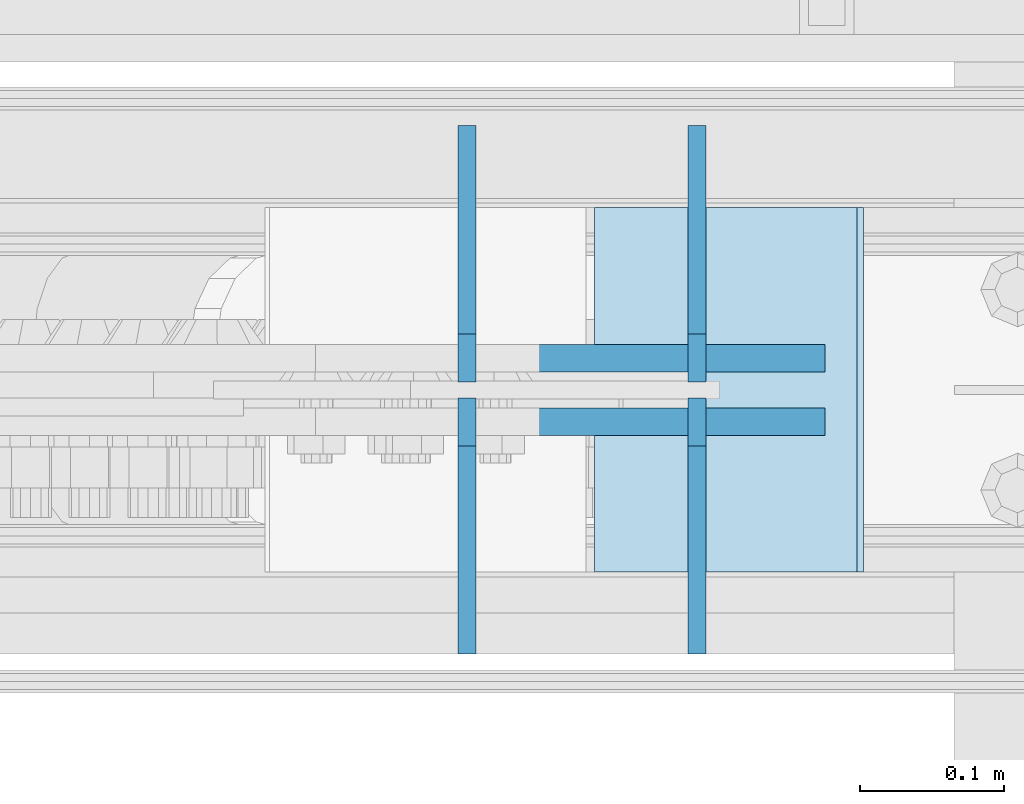
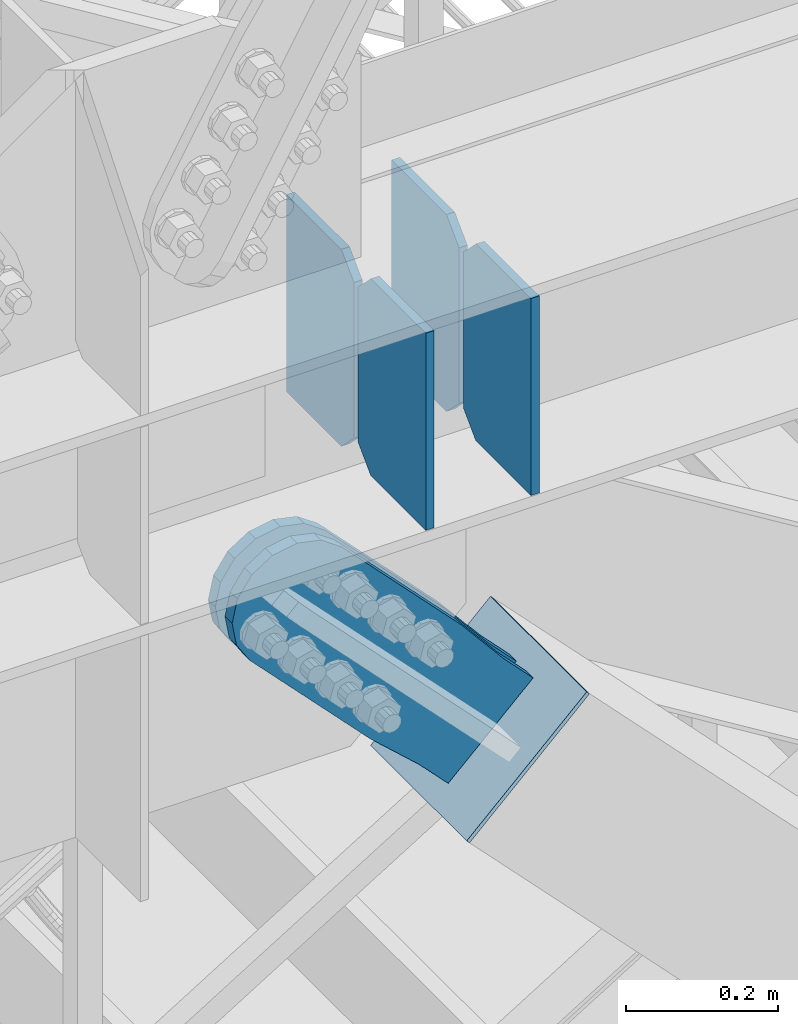
# One storey, part 3553 of 3843: 7 plates, 4 elements without a shape of their own.
"""IFC2X3 building model written with IfcOpenShell, lengths in millimetres."""

from ifc_helpers import new_model, si_unit, frame, origin_with_axes, place, context, subcontext, project, spatial, faceted_brep, material, type_object, element, aggregate, save


model = new_model("IFC2X3")

# Units and contexts
model_context = context("Model", 3, precision=1e-05, world=origin_with_axes())
body_context = subcontext(model_context, "Body", "Model", "MODEL_VIEW")
ifc_project = project(units=[si_unit("LENGTHUNIT", "METRE", prefix="MILLI"), si_unit("AREAUNIT", "SQUARE_METRE"), si_unit("VOLUMEUNIT", "CUBIC_METRE"), si_unit("MASSUNIT", "GRAM", prefix="KILO"), si_unit("TIMEUNIT", "SECOND"), si_unit("PLANEANGLEUNIT", "RADIAN"), si_unit("SOLIDANGLEUNIT", "STERADIAN"), si_unit("THERMODYNAMICTEMPERATUREUNIT", "DEGREE_CELSIUS"), si_unit("LUMINOUSINTENSITYUNIT", "LUMEN")], contexts=[model_context])

# Site, building, storey
site_placement = place(None, origin_with_axes())
site = spatial("IfcSite", under=ifc_project, at=site_placement, CompositionType="ELEMENT")
building_placement = place(site_placement, origin_with_axes())
building = spatial("IfcBuilding", under=site, at=building_placement, Name="Undefined", CompositionType="ELEMENT")
storey_placement = place(building_placement, origin_with_axes())
storey = spatial("IfcBuildingStorey", under=building, at=storey_placement, Name="Undefined", CompositionType="ELEMENT", Elevation=0.0)

# Assembly, plates
assembly_1_placement = place(storey_placement, origin_with_axes())
assembly_1 = element("IfcElementAssembly", 1, at=assembly_1_placement, inside=storey, Name="BEAM", AssemblyPlace="NOTDEFINED", PredefinedType="RIGID_FRAME")
ifc_material_1 = material(Name="STEEL/A572-50")
plate_type_1 = type_object("IfcPlateType", PredefinedType="NOTDEFINED")
plate_1_placement = place(assembly_1_placement, frame((81765.9734379999, 15004.25625, 34474.15), z_axis=(0.0, 1.0, 0.0), x_axis=(0.0, 0.0, 1.0)))
plate_1 = element("IfcPlate", 2, at=plate_1_placement, type_object=plate_type_1, material=ifc_material_1, Name="CB_BEAM", context=body_context, shape_type="Brep", body=[
    faceted_brep([(0.0, -6.34999999999854, 33.3375015258789), (0.0, -6.34999999999854, 178.59375), (0.0, 6.34999999999854, 178.59375), (0.0, 6.34999999999854, 33.3375015258789), (317.499999999985, -6.34999999999854, 178.59375), (317.499999999985, 6.34999999999854, 178.59375), (317.499999999985, -6.34999999999854, 33.3375015258789), (317.499999999985, 6.34999999999854, 33.3375015258789), (284.162498474107, -6.34999999999854, 0.0), (284.162498474107, 6.34999999999854, 0.0), (33.3375015258789, -6.34999999999854, 0.0), (33.3375015258789, 6.34999999999854, 0.0)], [[[0, 1, 2, 3]], [[1, 4, 5, 2]], [[4, 6, 7, 5]], [[6, 8, 9, 7]], [[8, 10, 11, 9]], [[10, 0, 3, 11]], [[5, 7, 9, 11, 3, 2]], [[10, 8, 6, 4, 1, 0]]]),
])
plate_2_placement = place(assembly_1_placement, frame((81765.9734379999, 14993.14375, 34474.15), z_axis=(0.0, -1.0, 0.0), x_axis=(0.0, 0.0, 1.0)))
plate_2 = element("IfcPlate", 3, at=plate_2_placement, type_object=plate_type_1, material=ifc_material_1, Name="CB_BEAM", context=body_context, shape_type="Brep", body=[
    faceted_brep([(0.0, -6.34999999999854, 33.3375015258789), (0.0, -6.34999999999854, 178.59375), (0.0, 6.34999999999854, 178.59375), (0.0, 6.34999999999854, 33.3375015258789), (317.499999999985, -6.34999999999854, 178.59375), (317.499999999985, 6.34999999999854, 178.59375), (317.499999999985, -6.34999999999854, 33.3375015258789), (317.499999999985, 6.34999999999854, 33.3375015258789), (284.162498474107, -6.34999999999854, 0.0), (284.162498474107, 6.34999999999854, 0.0), (33.3375015258789, -6.34999999999854, 0.0), (33.3375015258789, 6.34999999999854, 0.0)], [[[0, 1, 2, 3]], [[1, 4, 5, 2]], [[4, 6, 7, 5]], [[6, 8, 9, 7]], [[8, 10, 11, 9]], [[10, 0, 3, 11]], [[5, 7, 9, 11, 3, 2]], [[10, 8, 6, 4, 1, 0]]]),
])
plate_3_placement = place(assembly_1_placement, frame((81926.1124999999, 15004.25625, 34474.15), z_axis=(0.0, 1.0, 0.0), x_axis=(0.0, 0.0, 1.0)))
plate_3 = element("IfcPlate", 4, at=plate_3_placement, type_object=plate_type_1, material=ifc_material_1, Name="CB_BEAM", context=body_context, shape_type="Brep", body=[
    faceted_brep([(0.0, -6.34999999999854, 33.3375015258789), (0.0, -6.34999999999854, 178.59375), (0.0, 6.34999999999854, 178.59375), (0.0, 6.34999999999854, 33.3375015258789), (317.499999999985, -6.34999999999854, 178.59375), (317.499999999985, 6.34999999999854, 178.59375), (317.499999999985, -6.34999999999854, 33.3375015258789), (317.499999999985, 6.34999999999854, 33.3375015258789), (284.162498474107, -6.34999999999854, 0.0), (284.162498474107, 6.34999999999854, 0.0), (33.3375015258789, -6.34999999999854, 0.0), (33.3375015258789, 6.34999999999854, 0.0)], [[[0, 1, 2, 3]], [[1, 4, 5, 2]], [[4, 6, 7, 5]], [[6, 8, 9, 7]], [[8, 10, 11, 9]], [[10, 0, 3, 11]], [[5, 7, 9, 11, 3, 2]], [[10, 8, 6, 4, 1, 0]]]),
])
plate_4_placement = place(assembly_1_placement, frame((81926.1124999999, 14993.14375, 34474.15), z_axis=(0.0, -1.0, 0.0), x_axis=(0.0, 0.0, 1.0)))
plate_4 = element("IfcPlate", 5, at=plate_4_placement, type_object=plate_type_1, material=ifc_material_1, Name="CB_BEAM", context=body_context, shape_type="Brep", body=[
    faceted_brep([(0.0, -6.34999999999854, 33.3375015258789), (0.0, -6.34999999999854, 178.59375), (0.0, 6.34999999999854, 178.59375), (0.0, 6.34999999999854, 33.3375015258789), (317.499999999985, -6.34999999999854, 178.59375), (317.499999999985, 6.34999999999854, 178.59375), (317.499999999985, -6.34999999999854, 33.3375015258789), (317.499999999985, 6.34999999999854, 33.3375015258789), (284.162498474107, -6.34999999999854, 0.0), (284.162498474107, 6.34999999999854, 0.0), (33.3375015258789, -6.34999999999854, 0.0), (33.3375015258789, 6.34999999999854, 0.0)], [[[0, 1, 2, 3]], [[1, 4, 5, 2]], [[4, 6, 7, 5]], [[6, 8, 9, 7]], [[8, 10, 11, 9]], [[10, 0, 3, 11]], [[5, 7, 9, 11, 3, 2]], [[10, 8, 6, 4, 1, 0]]]),
])
aggregate(assembly_1, [plate_1, plate_2, plate_3, plate_4])

# Assembly, plate
assembly_2_placement = place(storey_placement, origin_with_axes())
assembly_2 = element("IfcElementAssembly", 6, at=assembly_2_placement, inside=storey, AssemblyPlace="NOTDEFINED", PredefinedType="RIGID_FRAME")
ifc_material_2 = material(Name="STEEL/A36")
plate_type_2 = type_object("IfcPlateType", PredefinedType="NOTDEFINED")
plate_5_placement = place(assembly_2_placement, frame((81966.9397793737, 15020.925, 34101.9215132179), z_axis=(-0.720244694304652, 0.0, -0.693720102293424), x_axis=(0.693720102293427, 0.0, -0.720244694304649)))
plate_5 = element("IfcPlate", 7, at=plate_5_placement, type_object=plate_type_2, material=ifc_material_2, context=body_context, shape_type="Brep", body=[
    faceted_brep([(0.0, -9.52500000000146, 0.0), (-101.59999999866, -9.52499999999418, -7.01164927375794), (-101.59999999866, 9.52499999999418, -7.01164927375794), (0.0, 9.52500000000146, 0.0), (-364.729297655074, -9.52499999999418, -7.01164927444188), (-364.729297655074, 9.52499999999418, -7.01164927444188), (-401.787405121293, -9.52499999999418, 0.359666612348519), (-401.787405121293, 9.52499999999418, 0.359666612348519), (-433.203751657995, -9.52499999999418, 21.3513982502482), (-433.203751657995, 9.52499999999418, 21.3513982502482), (-454.195483294687, -9.52499999999418, 52.7677447877504), (-454.195483294687, 9.52499999999418, 52.7677447877504), (-461.566799180051, -9.52499999999418, 89.8258492000314), (-461.566799180051, 9.52499999999418, 89.8258492000314), (-454.195483292249, -9.52499999999418, 126.883956664562), (-454.195483292249, 9.52499999999418, 126.883956664562), (-433.203751654662, -9.52499999999418, 158.300303199998), (-433.203751654662, 9.52499999999418, 158.300303199998), (-401.787405118426, -9.52499999999418, 179.292034836384), (-401.787405118426, 9.52499999999418, 179.292034836384), (-364.729299177612, -9.52499999999418, 186.663350722738), (-364.729299177612, 9.52499999999418, 186.663350722738), (-101.5999999907, -9.52499999999418, 186.663350723451), (-101.5999999907, 9.52499999999418, 186.663350723451), (7.37782102078199e-09, -9.52499999999418, 179.651701450231), (7.37782102078199e-09, 9.52499999999418, 179.651701450231), (69.8500000062704, -9.52499999999418, 179.651701450392), (69.8500000062704, 9.52499999999418, 179.651701450392), (69.8499999979995, -9.52499999999418, -4.00177668780088e-10), (69.8499999979995, 9.52499999999418, -4.00177668780088e-10)], [[[0, 1, 2, 3]], [[1, 4, 5, 2]], [[4, 6, 7, 5]], [[6, 8, 9, 7]], [[8, 10, 11, 9]], [[10, 12, 13, 11]], [[12, 14, 15, 13]], [[14, 16, 17, 15]], [[16, 18, 19, 17]], [[18, 20, 21, 19]], [[20, 22, 23, 21]], [[22, 24, 25, 23]], [[24, 26, 27, 25]], [[26, 28, 29, 27]], [[28, 0, 3, 29]], [[5, 7, 9, 11, 13, 15, 17, 19, 21, 23, 25, 27, 29, 3, 2]], [[28, 26, 24, 22, 20, 18, 16, 14, 12, 10, 8, 6, 4, 1, 0]]]),
])
aggregate(assembly_2, [plate_5])

assembly_3_placement = place(storey_placement, origin_with_axes())
assembly_3 = element("IfcElementAssembly", 8, at=assembly_3_placement, inside=storey, AssemblyPlace="NOTDEFINED", PredefinedType="RIGID_FRAME")
plate_6_placement = place(assembly_3_placement, frame((81966.9397793737, 14976.475, 34101.9215132179), z_axis=(-0.720244694304652, 0.0, -0.693720102293424), x_axis=(0.693720102293427, 0.0, -0.720244694304649)))
plate_6 = element("IfcPlate", 9, at=plate_6_placement, type_object=plate_type_2, material=ifc_material_2, context=body_context, shape_type="Brep", body=[
    faceted_brep([(0.0, -9.52500000000146, 0.0), (-101.59999999866, -9.52499999999418, -7.01164927375794), (-101.59999999866, 9.52499999999418, -7.01164927375794), (0.0, 9.52500000000146, 0.0), (-364.729297655074, -9.52499999999418, -7.01164927444188), (-364.729297655074, 9.52499999999418, -7.01164927444188), (-401.787405121293, -9.52499999999418, 0.359666612348519), (-401.787405121293, 9.52499999999418, 0.359666612348519), (-433.203751657995, -9.52499999999418, 21.3513982502482), (-433.203751657995, 9.52499999999418, 21.3513982502482), (-454.195483294687, -9.52499999999418, 52.7677447877504), (-454.195483294687, 9.52499999999418, 52.7677447877504), (-461.566799180051, -9.52499999999418, 89.8258492000314), (-461.566799180051, 9.52499999999418, 89.8258492000314), (-454.195483292249, -9.52499999999418, 126.883956664562), (-454.195483292249, 9.52499999999418, 126.883956664562), (-433.203751654662, -9.52499999999418, 158.300303199998), (-433.203751654662, 9.52499999999418, 158.300303199998), (-401.787405118426, -9.52499999999418, 179.292034836384), (-401.787405118426, 9.52499999999418, 179.292034836384), (-364.729299177612, -9.52499999999418, 186.663350722738), (-364.729299177612, 9.52499999999418, 186.663350722738), (-101.5999999907, -9.52499999999418, 186.663350723451), (-101.5999999907, 9.52499999999418, 186.663350723451), (7.37782102078199e-09, -9.52499999999418, 179.651701450231), (7.37782102078199e-09, 9.52499999999418, 179.651701450231), (69.8500000062704, -9.52499999999418, 179.651701450392), (69.8500000062704, 9.52499999999418, 179.651701450392), (69.8499999979995, -9.52499999999418, -4.00177668780088e-10), (69.8499999979995, 9.52499999999418, -4.00177668780088e-10)], [[[0, 1, 2, 3]], [[1, 4, 5, 2]], [[4, 6, 7, 5]], [[6, 8, 9, 7]], [[8, 10, 11, 9]], [[10, 12, 13, 11]], [[12, 14, 15, 13]], [[14, 16, 17, 15]], [[16, 18, 19, 17]], [[18, 20, 21, 19]], [[20, 22, 23, 21]], [[22, 24, 25, 23]], [[24, 26, 27, 25]], [[26, 28, 29, 27]], [[28, 0, 3, 29]], [[5, 7, 9, 11, 13, 15, 17, 19, 21, 23, 25, 27, 29, 3, 2]], [[28, 26, 24, 22, 20, 18, 16, 14, 12, 10, 8, 6, 4, 1, 0]]]),
])
aggregate(assembly_3, [plate_6])

assembly_4_placement = place(storey_placement, origin_with_axes())
assembly_4 = element("IfcElementAssembly", 10, at=assembly_4_placement, inside=storey, Name="Plate", AssemblyPlace="NOTDEFINED", PredefinedType="RIGID_FRAME")
plate_type_3 = type_object("IfcPlateType", PredefinedType="NOTDEFINED")
plate_7_placement = place(assembly_4_placement, frame((81857.0258986224, 15125.7, 33903.482746869), z_axis=(0.720244694304641, 0.0, 0.693720102293435), x_axis=(0.0, -1.0, 0.0)))
plate_7 = element("IfcPlate", 11, at=plate_7_placement, type_object=plate_type_3, material=ifc_material_2, Name="Plate", context=body_context, shape_type="Brep", body=[
    faceted_brep([(0.0, -3.17499999999927, 0.0), (0.0, -3.17499999965185, 254.000000005151), (0.0, 3.17500000035216, 254.000000005166), (0.0, 3.17499999999927, 0.0), (254.0, -3.17499999965185, 254.000000005151), (254.0, 3.17500000035216, 254.000000005166), (254.0, -3.17500000000291, 0.0), (254.0, 3.17499999999927, 1.45519152283669e-11)], [[[0, 1, 2, 3]], [[1, 4, 5, 2]], [[4, 6, 7, 5]], [[6, 0, 3, 7]], [[5, 7, 3, 2]], [[6, 4, 1, 0]]]),
])
aggregate(assembly_4, [plate_7])

save(model, "model.ifc")
